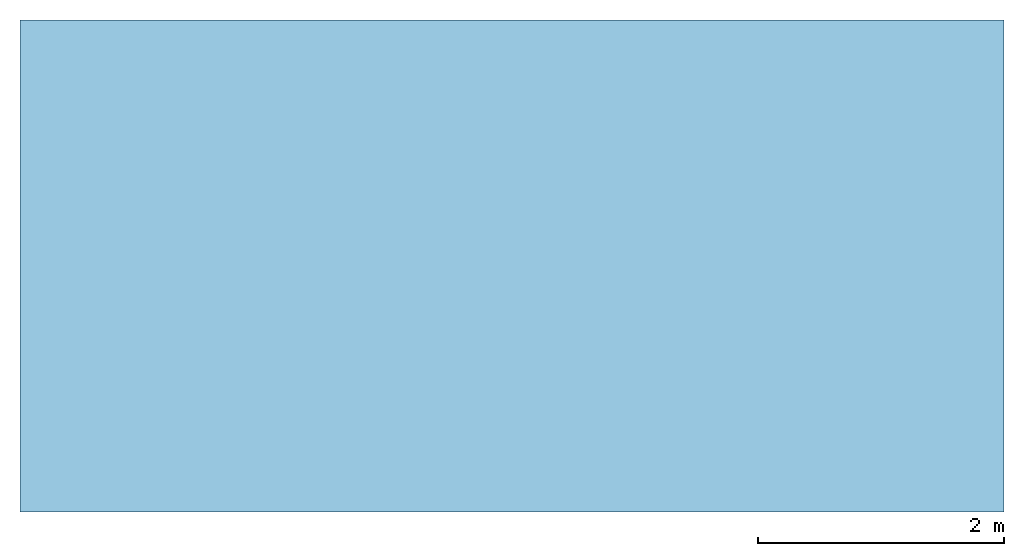
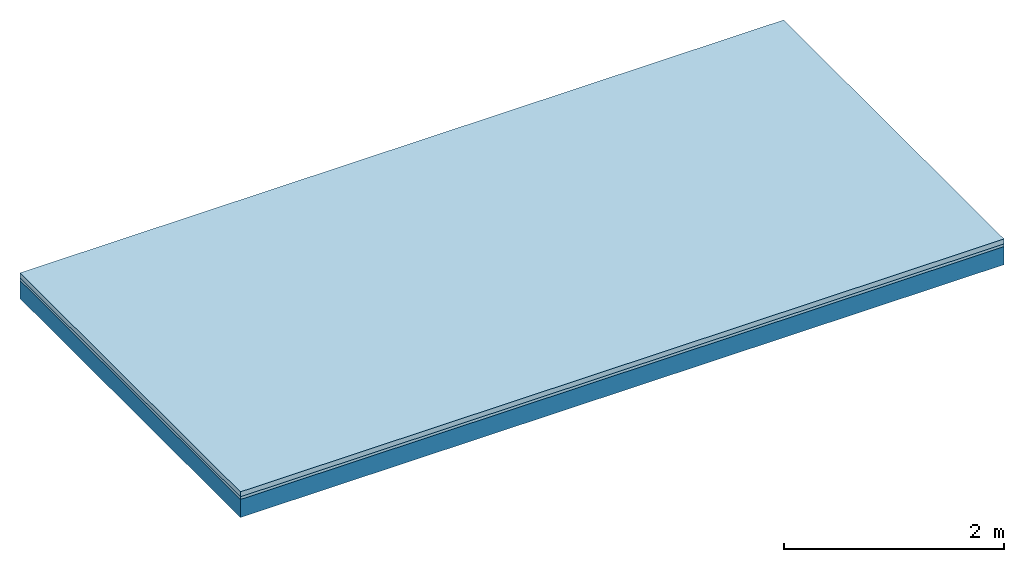
# One storey: 2 plates, 1 member, 1 element without a shape of its own.
"""IFC4 building model written with IfcOpenShell, lengths in metres."""

from ifc_helpers import new_model, si_unit, derived_unit, direction, frame, frame_2d, origin, origin_with_axes, place, context, project, spatial, rectangle, extrude, material, layer, layer_set, type_object, element, aggregate, save


model = new_model("IFC4")

# Units and contexts
plan_context = context("Plan", 3, precision=1e-05, world=origin(), true_north=direction((0.0, 1.0)))
model_context = context("Model", 3, precision=1e-05, world=origin(), true_north=direction((0.0, 1.0)))
ifc_project = project(units=[si_unit("LENGTHUNIT", "METRE"), derived_unit("SOUNDPRESSUREUNIT", [(si_unit("PRESSUREUNIT", "PASCAL", prefix="MICRO"), 0)]), si_unit("ENERGYUNIT", "JOULE", prefix="MEGA"), si_unit("MASSUNIT", "GRAM", prefix="KILO"), derived_unit("THERMALTRANSMITTANCEUNIT", [(si_unit("POWERUNIT", "WATT"), 1), (si_unit("AREAUNIT", "SQUARE_METRE"), -1), (si_unit("THERMODYNAMICTEMPERATUREUNIT", "KELVIN"), -1)]), derived_unit("AREADENSITYUNIT", [(si_unit("MASSUNIT", "GRAM", prefix="KILO"), 1), (si_unit("AREAUNIT", "SQUARE_METRE"), -1)]), derived_unit("USERDEFINED", [(si_unit("ENERGYUNIT", "JOULE", prefix="MEGA"), 1), (si_unit("AREAUNIT", "SQUARE_METRE"), -1)])], contexts=[plan_context, model_context])

# Site, building, storey
site = spatial("IfcSite", under=ifc_project)
building_placement = place(None, origin())
building = spatial("IfcBuilding", under=site, at=building_placement)
storey_placement = place(building_placement, origin())
storey = spatial("IfcBuildingStorey", under=building, at=storey_placement)

# Slab, member, plates
ifc_material_1 = material(Category="04.005")
ifc_layer_1 = layer(ifc_material_1, 0.055, Name="On-material")
ifc_material_2 = material()
ifc_layer_2 = layer(ifc_material_2, 0.03, Name="Impact sound insulation")
ifc_layer_3 = layer(None, 0.2, Name="Supporting structure")
ifc_layer_set = layer_set([ifc_layer_1, ifc_layer_2, ifc_layer_3])
slab_type = type_object("IfcSlabType", Name="A0839", PredefinedType="NOTDEFINED", material=ifc_layer_set)
slab_placement = place(None, frame((0.0, 0.0, 0.0), z_axis=(0.0, 0.0, -1.0), x_axis=(1.0, 0.0, 0.0)))
slab = element("IfcSlab", 1, at=slab_placement, inside=storey, type_object=slab_type, material=ifc_layer_set, Name="Slab #1")
ifc_material_3 = material()
member_placement = place(slab_placement, origin())
member = element("IfcMember", 2, at=member_placement, material=ifc_material_3, Name="Supporting structure", context=plan_context, shape_type="SweptSolid", body=[
    extrude(rectangle(XDim=1.0, YDim=0.2, at=frame_2d((0.5, 0.1), x_axis=(1.0, 0.0))), frame((0.0, 4.0, 0.085), z_axis=(0.0, -1.0, 0.0), x_axis=(1.0, 0.0, 0.0)), (0.0, 0.0, 1.0), 4.0),
    extrude(rectangle(XDim=1.0, YDim=0.2, at=frame_2d((0.5, 0.1), x_axis=(1.0, 0.0))), frame((1.0, 4.0, 0.085), z_axis=(0.0, -1.0, 0.0), x_axis=(1.0, 0.0, 0.0)), (0.0, 0.0, 1.0), 4.0),
    extrude(rectangle(XDim=1.0, YDim=0.2, at=frame_2d((0.5, 0.1), x_axis=(1.0, 0.0))), frame((2.0, 4.0, 0.085), z_axis=(0.0, -1.0, 0.0), x_axis=(1.0, 0.0, 0.0)), (0.0, 0.0, 1.0), 4.0),
    extrude(rectangle(XDim=1.0, YDim=0.2, at=frame_2d((0.5, 0.1), x_axis=(1.0, 0.0))), frame((3.0, 4.0, 0.085), z_axis=(0.0, -1.0, 0.0), x_axis=(1.0, 0.0, 0.0)), (0.0, 0.0, 1.0), 4.0),
    extrude(rectangle(XDim=1.0, YDim=0.2, at=frame_2d((0.5, 0.1), x_axis=(1.0, 0.0))), frame((4.0, 4.0, 0.085), z_axis=(0.0, -1.0, 0.0), x_axis=(1.0, 0.0, 0.0)), (0.0, 0.0, 1.0), 4.0),
    extrude(rectangle(XDim=1.0, YDim=0.2, at=frame_2d((0.5, 0.1), x_axis=(1.0, 0.0))), frame((5.0, 4.0, 0.085), z_axis=(0.0, -1.0, 0.0), x_axis=(1.0, 0.0, 0.0)), (0.0, 0.0, 1.0), 4.0),
    extrude(rectangle(XDim=1.0, YDim=0.2, at=frame_2d((0.5, 0.1), x_axis=(1.0, 0.0))), frame((6.0, 4.0, 0.085), z_axis=(0.0, -1.0, 0.0), x_axis=(1.0, 0.0, 0.0)), (0.0, 0.0, 1.0), 4.0),
    extrude(rectangle(XDim=1.0, YDim=0.2, at=frame_2d((0.5, 0.1), x_axis=(1.0, 0.0))), frame((7.0, 4.0, 0.085), z_axis=(0.0, -1.0, 0.0), x_axis=(1.0, 0.0, 0.0)), (0.0, 0.0, 1.0), 4.0),
])
plate_1_placement = place(slab_placement, origin())
plate_1 = element("IfcPlate", 3, at=plate_1_placement, material=ifc_material_1, Name="On-material", context=plan_context, shape_type="SweptSolid", body=[
    extrude(rectangle(XDim=8.0, YDim=4.0, at=frame_2d((4.0, 2.0), x_axis=(1.0, 0.0))), origin_with_axes(), (0.0, 0.0, 1.0), 0.055),
])
plate_2_placement = place(slab_placement, origin())
plate_2 = element("IfcPlate", 4, at=plate_2_placement, material=ifc_material_2, Name="Impact sound insulation", context=plan_context, shape_type="SweptSolid", body=[
    extrude(rectangle(XDim=8.0, YDim=4.0, at=frame_2d((4.0, 2.0), x_axis=(1.0, 0.0))), frame((0.0, 0.0, 0.055), z_axis=(0.0, 0.0, 1.0), x_axis=(1.0, 0.0, 0.0)), (0.0, 0.0, 1.0), 0.03),
])
aggregate(slab, [plate_1, plate_2, member])

save(model, "model.ifc")
